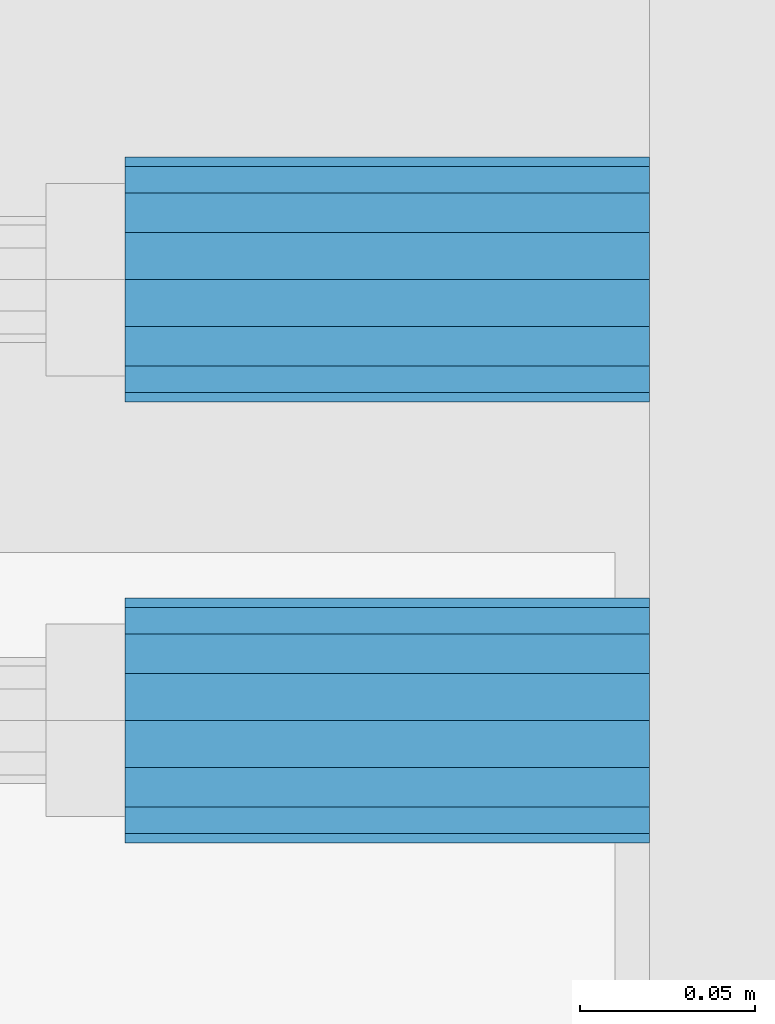
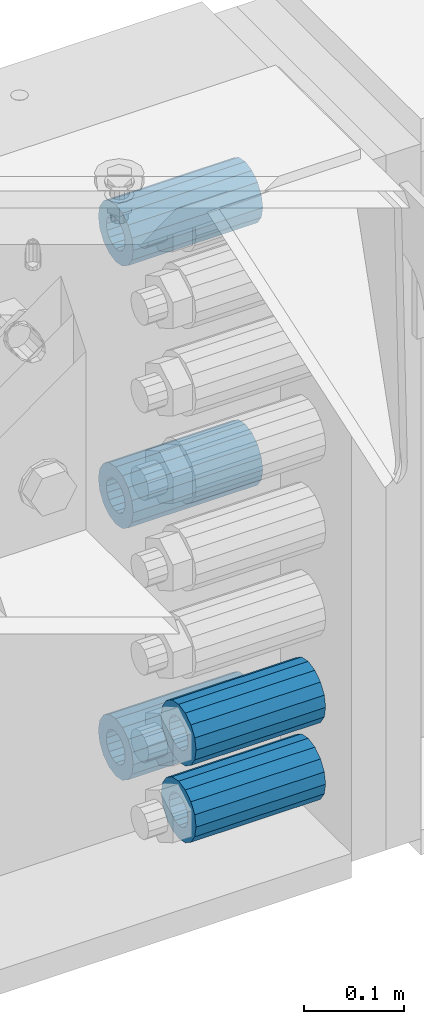
# One storey, part 178 of 257: 5 beams.
"""IFC2X3 building model written with IfcOpenShell, lengths in millimetres."""

import ifcopenshell
import ifcopenshell.guid

model = None  # the IFC model being written
_history = None  # IfcOwnerHistory: only IFC2X3 demands one
_inside = {}  # id of a spatial element -> (the spatial element, [elements in it])
_under = {}  # id of a project, library or spatial element -> (it, [spatial elements below it])
_declared = {}  # id of a project -> (the project, [libraries it declares])
_typed = {}  # id of a type object -> (the type object, [elements of that type])
_made_of = {}  # id of a material, layer set ... -> (it, [elements and type objects made of it])


def new_model(schema):
    """Start an empty IFC model of exactly this schema.

    Asked for "IFC4X3", IfcOpenShell would pick the latest addendum, in which some entities
    have other attributes; the version numbers below select the first issue.
    IFC2X3 requires an IfcOwnerHistory on every rooted entity: one is made here for all.
    """
    global model, _history
    if schema == "IFC4X3":
        model = ifcopenshell.file(schema_version=(4, 3, 0, 0))
    else:
        model = ifcopenshell.file(schema=schema)
    _inside.clear()
    _under.clear()
    _declared.clear()
    _typed.clear()
    _made_of.clear()
    _history = None
    if model.schema == "IFC2X3":
        org = make("IfcOrganization", Name="unknown")
        user = make(
            "IfcPersonAndOrganization",
            ThePerson=make("IfcPerson", FamilyName="unknown"),
            TheOrganization=org,
        )
        app = make(
            "IfcApplication",
            ApplicationDeveloper=org,
            Version="unknown",
            ApplicationFullName="unknown",
            ApplicationIdentifier="unknown",
        )
        _history = make(
            "IfcOwnerHistory",
            OwningUser=user,
            OwningApplication=app,
            ChangeAction="ADDED",
            CreationDate=0,
        )
    return model


def make(cls, **values):
    """One entity of the class cls with the attributes given. An attribute that is None is left unset."""
    return model.create_entity(
        cls, **{name: value for name, value in values.items() if value is not None}
    )


def rooted(cls, **values):
    """An entity with a GlobalId (a new one), such as an element, a storey or a relation."""
    return make(cls, GlobalId=ifcopenshell.guid.new(), OwnerHistory=_history, **values)


def si_unit(unit_type, name, prefix=None):
    """IfcSIUnit, for example si_unit("LENGTHUNIT", "METRE", prefix="MILLI")."""
    return make("IfcSIUnit", UnitType=unit_type, Prefix=prefix, Name=name)


def assignment(units):
    """IfcUnitAssignment: the units of a project."""
    return None if units is None else make("IfcUnitAssignment", Units=units)


def point(xyz):
    """IfcCartesianPoint."""
    return None if xyz is None else make("IfcCartesianPoint", Coordinates=xyz)


def direction(xyz):
    """IfcDirection."""
    return None if xyz is None else make("IfcDirection", DirectionRatios=xyz)


def frame(location, z_axis=None, x_axis=None):
    """IfcAxis2Placement3D, a coordinate frame: its origin and axes. An axis left out is left unset."""
    return make(
        "IfcAxis2Placement3D",
        Location=point(location),
        Axis=direction(z_axis),
        RefDirection=direction(x_axis),
    )


def origin_with_axes():
    """The frame at (0, 0, 0) with the z axis (0, 0, 1) and the x axis (1, 0, 0) written out."""
    return frame((0.0, 0.0, 0.0), z_axis=(0.0, 0.0, 1.0), x_axis=(1.0, 0.0, 0.0))


def place(relative_to, where):
    """IfcLocalPlacement: puts the frame where relative to a parent placement (None: the world)."""
    return make(
        "IfcLocalPlacement", PlacementRelTo=relative_to, RelativePlacement=where
    )


def context(
    kind, dimensions, precision=None, world=None, true_north=None, identifier=None
):
    """IfcGeometricRepresentationContext, for example the 3D "Model" context."""
    return make(
        "IfcGeometricRepresentationContext",
        ContextIdentifier=identifier,
        ContextType=kind,
        CoordinateSpaceDimension=dimensions,
        Precision=precision,
        WorldCoordinateSystem=world,
        TrueNorth=true_north,
    )


def subcontext(parent, identifier, kind, view, scale=None):
    """IfcGeometricRepresentationSubContext, for example "Body" below "Model"."""
    return make(
        "IfcGeometricRepresentationSubContext",
        ContextIdentifier=identifier,
        ContextType=kind,
        ParentContext=parent,
        TargetScale=scale,
        TargetView=view,
    )


def project(units=None, contexts=None):
    """IfcProject with its units and contexts."""
    return rooted(
        "IfcProject",
        Name="project",
        RepresentationContexts=contexts,
        UnitsInContext=assignment(units),
    )


def spatial(cls, under=None, at=None, **own):
    """A site, building, storey or space (cls), placed at a placement, below another one or the project."""
    s = rooted(cls, ObjectPlacement=at, **own)
    if under is not None:
        _under.setdefault(under.id(), (under, []))[1].append(s)
    return s


def faces_of(points, faces, orient=None, outer=None):
    """IfcFace entities. A face is a list of loops; a loop is a list of indices into points, from 0.

    orient and outer hold one flag for each loop. By default every Orientation is true, the
    first loop of a face is its IfcFaceOuterBound and the others are IfcFaceBound.
    """
    made = []
    for i, loops in enumerate(faces):
        bounds = []
        for j, loop in enumerate(loops):
            is_outer = j == 0 if outer is None else outer[i][j]
            bounds.append(
                make(
                    "IfcFaceOuterBound" if is_outer else "IfcFaceBound",
                    Bound=make("IfcPolyLoop", Polygon=[points[k] for k in loop]),
                    Orientation=True if orient is None else orient[i][j],
                )
            )
        made.append(make("IfcFace", Bounds=bounds))
    return made


def faceted_brep(points, faces, orient=None, outer=None, voids=None):
    """IfcFacetedBrep: a solid bounded by flat faces; with voids (closed shells), ...WithVoids."""
    shared = [point(p) for p in points]
    hull = make("IfcClosedShell", CfsFaces=faces_of(shared, faces, orient, outer))
    if voids is None:
        return make("IfcFacetedBrep", Outer=hull)
    return make(
        "IfcFacetedBrepWithVoids",
        Outer=hull,
        Voids=[
            make(cls, CfsFaces=faces_of(shared, fs, o, b)) for cls, fs, o, b in voids
        ],
    )


def shape(context_of_items, identifier, shape_type, items):
    """IfcShapeRepresentation: the items that make up one representation, for example the "Body"."""
    return make(
        "IfcShapeRepresentation",
        ContextOfItems=context_of_items,
        RepresentationIdentifier=identifier,
        RepresentationType=shape_type,
        Items=items,
    )


def material(Name=None, Category=None):
    """IfcMaterial."""
    return make("IfcMaterial", Name=Name, Category=Category)


def made_of(thing, what):
    """Note that an element or type object is made of a material, layer set ...; save() writes the relation."""
    if what is not None:
        _made_of.setdefault(what.id(), (what, []))[1].append(thing)
    return thing


def type_object(cls, material=None, **own):
    """A type object (cls), such as IfcWallType, which elements share."""
    return made_of(rooted(cls, **own), material)


def element(
    cls,
    number,
    at=None,
    inside=None,
    cuts=None,
    type_object=None,
    material=None,
    context=None,
    identifier="Body",
    shape_type=None,
    held_by="IfcProductDefinitionShape",
    body=None,
    shapes=None,
    **own,
):
    """One element of the class cls, such as IfcWall. Its Tag is "e" and its number.

    at: its placement. inside: the storey or other place that contains it. cuts: it is an
    opening in that element (IfcRelVoidsElement). A single representation is given by context,
    identifier, shape_type and body (its items); several are given by shapes. held_by: the class
    of the entity that holds the representations. save() writes the other relations.
    """
    e = rooted(cls, Tag="e%d" % number, ObjectPlacement=at, **own)
    if body is not None:
        shapes = [shape(context, identifier, shape_type, body)]
    if shapes is not None:
        e.Representation = make(held_by, Representations=shapes)
    if inside is not None:
        _inside.setdefault(inside.id(), (inside, []))[1].append(e)
    if cuts is not None:
        rooted(
            "IfcRelVoidsElement", RelatingBuildingElement=cuts, RelatedOpeningElement=e
        )
    if type_object is not None:
        _typed.setdefault(type_object.id(), (type_object, []))[1].append(e)
    return made_of(e, material)


def aggregate(whole, parts):
    """IfcRelAggregates: a whole, such as a stair, and the parts it consists of."""
    return rooted("IfcRelAggregates", RelatingObject=whole, RelatedObjects=parts)


def save(model, path):
    """Write the relations noted so far, then the file.

    IfcRelAggregates (storeys below a building ...), IfcRelContainedInSpatialStructure (elements
    in a storey), IfcRelDefinesByType, IfcRelAssociatesMaterial and IfcRelDeclares: one each for
    every whole, place, type object, material and project.
    """
    for whole, parts in _under.values():
        aggregate(whole, parts)
    for where, things in _inside.values():
        rooted(
            "IfcRelContainedInSpatialStructure",
            RelatedElements=things,
            RelatingStructure=where,
        )
    for kind, things in _typed.values():
        rooted("IfcRelDefinesByType", RelatedObjects=things, RelatingType=kind)
    for what, things in _made_of.values():
        rooted("IfcRelAssociatesMaterial", RelatedObjects=things, RelatingMaterial=what)
    for by, libraries in _declared.values():
        rooted("IfcRelDeclares", RelatingContext=by, RelatedDefinitions=libraries)
    model.write(path)


model = new_model("IFC2X3")

# Units and contexts
model_context = context("Model", 3, precision=1e-05, world=origin_with_axes())
body_context = subcontext(model_context, "Body", "Model", "MODEL_VIEW")
ifc_project = project(units=[si_unit("LENGTHUNIT", "METRE", prefix="MILLI"), si_unit("AREAUNIT", "SQUARE_METRE"), si_unit("VOLUMEUNIT", "CUBIC_METRE"), si_unit("MASSUNIT", "GRAM", prefix="KILO"), si_unit("TIMEUNIT", "SECOND"), si_unit("PLANEANGLEUNIT", "RADIAN"), si_unit("SOLIDANGLEUNIT", "STERADIAN"), si_unit("THERMODYNAMICTEMPERATUREUNIT", "DEGREE_CELSIUS"), si_unit("LUMINOUSINTENSITYUNIT", "LUMEN")], contexts=[model_context])

# Site, building, storey
site_placement = place(None, origin_with_axes())
site = spatial("IfcSite", under=ifc_project, at=site_placement, CompositionType="ELEMENT")
building_placement = place(site_placement, origin_with_axes())
building = spatial("IfcBuilding", under=site, at=building_placement, Name="Standard", CompositionType="ELEMENT")
storey_placement = place(building_placement, origin_with_axes())
storey = spatial("IfcBuildingStorey", under=building, at=storey_placement, Name="Undefined", CompositionType="ELEMENT", Elevation=0.0)

# Beams
ifc_material = material()
beam_type = type_object("IfcBeamType", PredefinedType="NOTDEFINED")
beam_1_placement = place(storey_placement, frame((59117.0, 12063.0, -499.0), z_axis=(0.0, 0.0, 1.0), x_axis=(1.0, 0.0, 0.0)))
element("IfcBeam", 1, at=beam_1_placement, inside=storey, type_object=beam_type, material=ifc_material, context=body_context, shape_type="Brep", body=[
    faceted_brep([(-1.3120632047503e-07, -18.9999999995493, -6.27187546342611e-09), (0.0, -17.5537111177146, 7.27098521493672), (150.0, -17.5537111177146, 7.27098521493672), (150.0, -19.0, 0.0), (0.0, -13.4350288425449, 13.4350288425444), (150.0, -13.4350288425449, 13.4350288425444), (0.0, -7.27098521493645, 17.5537111177144), (150.0, -7.27098521493645, 17.5537111177144), (-6.33792751614237e-09, 4.50654624728486e-10, 18.9999999937208), (150.0, 0.0, 19.0), (0.0, 7.27098521493645, 17.5537111177144), (150.0, 7.27098521493645, 17.5537111177144), (0.0, 13.4350288425449, 13.4350288425444), (150.0, 13.4350288425449, 13.4350288425444), (0.0, 17.5537111177146, 7.2709852149367), (150.0, 17.5537111177146, 7.2709852149367), (1.33208345687308e-07, 19.0000000004507, -6.27187546342611e-09), (150.0, 19.0, 0.0), (0.0, 17.5537111177146, -7.2709852149367), (150.0, 17.5537111177146, -7.2709852149367), (0.0, 13.4350288425449, -13.4350288425444), (150.0, 13.4350288425449, -13.4350288425444), (0.0, 7.27098521493645, -17.5537111177144), (150.0, 7.27098521493645, -17.5537111177144), (8.33983904158231e-09, 4.50654624728486e-10, -19.0000000062719), (150.0, 0.0, -19.0), (0.0, -7.27098521493645, -17.5537111177144), (150.0, -7.27098521493645, -17.5537111177144), (0.0, -13.4350288425449, -13.4350288425444), (150.0, -13.4350288425449, -13.4350288425444), (0.0, -17.5537111177146, -7.2709852149367), (150.0, -17.5537111177146, -7.2709852149367), (7.27595761418343e-12, -35.0, 0.0), (1.45519152283669e-11, -32.335783637895, -13.3939201327781), (150.0, -32.3357836378955, -13.3939201327782), (150.0, -35.0, 0.0), (7.27595761418343e-12, -24.7487373415292, -24.748737341529), (150.0, -24.7487373415288, -24.7487373415292), (7.27595761418343e-12, -13.3939201327781, -32.335783637895), (150.0, -13.3939201327785, -32.335783637895), (7.27595761418343e-12, 0.0, -35.0), (150.0, 0.0, -35.0), (7.27595761418343e-12, 13.3939201327782, -32.335783637895), (150.0, 13.3939201327785, -32.335783637895), (7.27595761418343e-12, 24.7487373415292, -24.748737341529), (150.0, 24.7487373415288, -24.7487373415292), (1.45519152283669e-11, 32.335783637895, -13.3939201327781), (150.0, 32.3357836378955, -13.3939201327781), (7.27595761418343e-12, 35.0, 0.0), (150.0, 35.0, 0.0), (7.27595761418343e-12, 32.335783637895, 13.3939201327782), (150.0, 32.3357836378955, 13.3939201327781), (7.27595761418343e-12, 24.7487373415292, 24.7487373415291), (150.0, 24.7487373415288, 24.7487373415292), (1.45519152283669e-11, 13.3939201327781, 32.335783637895), (150.0, 13.3939201327785, 32.335783637895), (1.45519152283669e-11, 0.0, 35.0000000000001), (150.0, 0.0, 35.0), (1.45519152283669e-11, -13.3939201327781, 32.335783637895), (150.0, -13.3939201327785, 32.335783637895), (7.27595761418343e-12, -24.7487373415292, 24.7487373415291), (150.0, -24.7487373415288, 24.7487373415292), (7.27595761418343e-12, -32.335783637895, 13.3939201327782), (150.0, -32.3357836378955, 13.3939201327781)], [[[0, 1, 2, 3]], [[1, 4, 5, 2]], [[4, 6, 7, 5]], [[6, 8, 9, 7]], [[8, 10, 11, 9]], [[10, 12, 13, 11]], [[12, 14, 15, 13]], [[14, 16, 17, 15]], [[16, 18, 19, 17]], [[18, 20, 21, 19]], [[20, 22, 23, 21]], [[22, 24, 25, 23]], [[24, 26, 27, 25]], [[26, 28, 29, 27]], [[28, 30, 31, 29]], [[30, 0, 3, 31]], [[32, 33, 34, 35]], [[33, 36, 37, 34]], [[36, 38, 39, 37]], [[38, 40, 41, 39]], [[40, 42, 43, 41]], [[42, 44, 45, 43]], [[44, 46, 47, 45]], [[46, 48, 49, 47]], [[48, 50, 51, 49]], [[50, 52, 53, 51]], [[52, 54, 55, 53]], [[54, 56, 57, 55]], [[56, 58, 59, 57]], [[58, 60, 61, 59]], [[60, 62, 63, 61]], [[62, 32, 35, 63]], [[37, 39, 41, 43, 45, 47, 49, 51, 53, 55, 57, 59, 61, 63, 35, 34], [5, 7, 9, 11, 13, 15, 17, 19, 21, 23, 25, 27, 29, 31, 3, 2]], [[62, 60, 58, 56, 54, 52, 50, 48, 46, 44, 42, 40, 38, 36, 33, 32], [30, 28, 26, 24, 22, 20, 18, 16, 14, 12, 10, 8, 6, 4, 1, 0]]]),
])
beam_2_placement = place(storey_placement, frame((59117.0, 12063.0, -178.0), z_axis=(0.0, 0.0, 1.0), x_axis=(1.0, 0.0, 0.0)))
element("IfcBeam", 2, at=beam_2_placement, inside=storey, type_object=beam_type, material=ifc_material, context=body_context, shape_type="Brep", body=[
    faceted_brep([(-1.3120632047503e-07, -18.9999999995493, -6.27187546342611e-09), (0.0, -17.5537111177146, 7.27098521493672), (150.0, -17.5537111177146, 7.27098521493672), (150.0, -19.0, 0.0), (0.0, -13.4350288425449, 13.4350288425444), (150.0, -13.4350288425449, 13.4350288425444), (0.0, -7.27098521493645, 17.5537111177144), (150.0, -7.27098521493645, 17.5537111177144), (-6.33792751614237e-09, 4.50654624728486e-10, 18.9999999937208), (150.0, 0.0, 19.0), (0.0, 7.27098521493645, 17.5537111177144), (150.0, 7.27098521493645, 17.5537111177144), (0.0, 13.4350288425449, 13.4350288425444), (150.0, 13.4350288425449, 13.4350288425444), (0.0, 17.5537111177146, 7.2709852149367), (150.0, 17.5537111177146, 7.2709852149367), (1.33208345687308e-07, 19.0000000004507, -6.27187546342611e-09), (150.0, 19.0, 0.0), (0.0, 17.5537111177146, -7.2709852149367), (150.0, 17.5537111177146, -7.2709852149367), (0.0, 13.4350288425449, -13.4350288425444), (150.0, 13.4350288425449, -13.4350288425444), (0.0, 7.27098521493645, -17.5537111177144), (150.0, 7.27098521493645, -17.5537111177144), (8.33983904158231e-09, 4.50654624728486e-10, -19.0000000062719), (150.0, 0.0, -19.0), (0.0, -7.27098521493645, -17.5537111177144), (150.0, -7.27098521493645, -17.5537111177144), (0.0, -13.4350288425449, -13.4350288425444), (150.0, -13.4350288425449, -13.4350288425444), (0.0, -17.5537111177146, -7.2709852149367), (150.0, -17.5537111177146, -7.2709852149367), (7.27595761418343e-12, -35.0, 0.0), (1.45519152283669e-11, -32.335783637895, -13.3939201327781), (150.0, -32.3357836378955, -13.3939201327782), (150.0, -35.0, 0.0), (7.27595761418343e-12, -24.7487373415292, -24.748737341529), (150.0, -24.7487373415288, -24.7487373415292), (7.27595761418343e-12, -13.3939201327781, -32.335783637895), (150.0, -13.3939201327785, -32.335783637895), (7.27595761418343e-12, 0.0, -35.0), (150.0, 0.0, -35.0), (7.27595761418343e-12, 13.3939201327782, -32.335783637895), (150.0, 13.3939201327785, -32.335783637895), (7.27595761418343e-12, 24.7487373415292, -24.748737341529), (150.0, 24.7487373415288, -24.7487373415292), (1.45519152283669e-11, 32.335783637895, -13.3939201327781), (150.0, 32.3357836378955, -13.3939201327781), (7.27595761418343e-12, 35.0, 0.0), (150.0, 35.0, 0.0), (7.27595761418343e-12, 32.335783637895, 13.3939201327782), (150.0, 32.3357836378955, 13.3939201327781), (7.27595761418343e-12, 24.7487373415292, 24.7487373415291), (150.0, 24.7487373415288, 24.7487373415292), (1.45519152283669e-11, 13.3939201327781, 32.335783637895), (150.0, 13.3939201327785, 32.335783637895), (1.45519152283669e-11, 0.0, 35.0000000000001), (150.0, 0.0, 35.0), (1.45519152283669e-11, -13.3939201327781, 32.335783637895), (150.0, -13.3939201327785, 32.335783637895), (7.27595761418343e-12, -24.7487373415292, 24.7487373415291), (150.0, -24.7487373415288, 24.7487373415292), (7.27595761418343e-12, -32.335783637895, 13.3939201327782), (150.0, -32.3357836378955, 13.3939201327781)], [[[0, 1, 2, 3]], [[1, 4, 5, 2]], [[4, 6, 7, 5]], [[6, 8, 9, 7]], [[8, 10, 11, 9]], [[10, 12, 13, 11]], [[12, 14, 15, 13]], [[14, 16, 17, 15]], [[16, 18, 19, 17]], [[18, 20, 21, 19]], [[20, 22, 23, 21]], [[22, 24, 25, 23]], [[24, 26, 27, 25]], [[26, 28, 29, 27]], [[28, 30, 31, 29]], [[30, 0, 3, 31]], [[32, 33, 34, 35]], [[33, 36, 37, 34]], [[36, 38, 39, 37]], [[38, 40, 41, 39]], [[40, 42, 43, 41]], [[42, 44, 45, 43]], [[44, 46, 47, 45]], [[46, 48, 49, 47]], [[48, 50, 51, 49]], [[50, 52, 53, 51]], [[52, 54, 55, 53]], [[54, 56, 57, 55]], [[56, 58, 59, 57]], [[58, 60, 61, 59]], [[60, 62, 63, 61]], [[62, 32, 35, 63]], [[37, 39, 41, 43, 45, 47, 49, 51, 53, 55, 57, 59, 61, 63, 35, 34], [5, 7, 9, 11, 13, 15, 17, 19, 21, 23, 25, 27, 29, 31, 3, 2]], [[62, 60, 58, 56, 54, 52, 50, 48, 46, 44, 42, 40, 38, 36, 33, 32], [30, 28, 26, 24, 22, 20, 18, 16, 14, 12, 10, 8, 6, 4, 1, 0]]]),
])
beam_3_placement = place(storey_placement, frame((59117.0, 11937.0, -713.0), z_axis=(0.0, 0.0, 1.0), x_axis=(1.0, 0.0, 0.0)))
element("IfcBeam", 3, at=beam_3_placement, inside=storey, type_object=beam_type, material=ifc_material, context=body_context, shape_type="Brep", body=[
    faceted_brep([(-1.3120632047503e-07, -18.9999999995493, -6.27187546342611e-09), (0.0, -17.5537111177146, 7.27098521493672), (150.0, -17.5537111177146, 7.27098521493672), (150.0, -19.0, 0.0), (0.0, -13.4350288425449, 13.4350288425444), (150.0, -13.4350288425449, 13.4350288425444), (0.0, -7.27098521493645, 17.5537111177144), (150.0, -7.27098521493645, 17.5537111177144), (-6.33792751614237e-09, 4.50654624728486e-10, 18.9999999937208), (150.0, 0.0, 19.0), (0.0, 7.27098521493645, 17.5537111177144), (150.0, 7.27098521493645, 17.5537111177144), (0.0, 13.4350288425449, 13.4350288425444), (150.0, 13.4350288425449, 13.4350288425444), (0.0, 17.5537111177146, 7.2709852149367), (150.0, 17.5537111177146, 7.2709852149367), (1.33208345687308e-07, 19.0000000004507, -6.27187546342611e-09), (150.0, 19.0, 0.0), (0.0, 17.5537111177146, -7.2709852149367), (150.0, 17.5537111177146, -7.2709852149367), (0.0, 13.4350288425449, -13.4350288425444), (150.0, 13.4350288425449, -13.4350288425444), (0.0, 7.27098521493645, -17.5537111177144), (150.0, 7.27098521493645, -17.5537111177144), (8.33983904158231e-09, 4.50654624728486e-10, -19.0000000062719), (150.0, 0.0, -19.0), (0.0, -7.27098521493645, -17.5537111177144), (150.0, -7.27098521493645, -17.5537111177144), (0.0, -13.4350288425449, -13.4350288425444), (150.0, -13.4350288425449, -13.4350288425444), (0.0, -17.5537111177146, -7.2709852149367), (150.0, -17.5537111177146, -7.2709852149367), (7.27595761418343e-12, -35.0, 0.0), (1.45519152283669e-11, -32.335783637895, -13.3939201327781), (150.0, -32.3357836378955, -13.3939201327782), (150.0, -35.0, 0.0), (7.27595761418343e-12, -24.7487373415292, -24.748737341529), (150.0, -24.7487373415288, -24.7487373415292), (7.27595761418343e-12, -13.3939201327781, -32.335783637895), (150.0, -13.3939201327785, -32.335783637895), (7.27595761418343e-12, 0.0, -35.0), (150.0, 0.0, -35.0), (7.27595761418343e-12, 13.3939201327782, -32.335783637895), (150.0, 13.3939201327785, -32.335783637895), (7.27595761418343e-12, 24.7487373415292, -24.748737341529), (150.0, 24.7487373415288, -24.7487373415292), (1.45519152283669e-11, 32.335783637895, -13.3939201327781), (150.0, 32.3357836378955, -13.3939201327781), (7.27595761418343e-12, 35.0, 0.0), (150.0, 35.0, 0.0), (7.27595761418343e-12, 32.335783637895, 13.3939201327782), (150.0, 32.3357836378955, 13.3939201327781), (7.27595761418343e-12, 24.7487373415292, 24.7487373415291), (150.0, 24.7487373415288, 24.7487373415292), (1.45519152283669e-11, 13.3939201327781, 32.335783637895), (150.0, 13.3939201327785, 32.335783637895), (1.45519152283669e-11, 0.0, 35.0000000000001), (150.0, 0.0, 35.0), (1.45519152283669e-11, -13.3939201327781, 32.335783637895), (150.0, -13.3939201327785, 32.335783637895), (7.27595761418343e-12, -24.7487373415292, 24.7487373415291), (150.0, -24.7487373415288, 24.7487373415292), (7.27595761418343e-12, -32.335783637895, 13.3939201327782), (150.0, -32.3357836378955, 13.3939201327781)], [[[0, 1, 2, 3]], [[1, 4, 5, 2]], [[4, 6, 7, 5]], [[6, 8, 9, 7]], [[8, 10, 11, 9]], [[10, 12, 13, 11]], [[12, 14, 15, 13]], [[14, 16, 17, 15]], [[16, 18, 19, 17]], [[18, 20, 21, 19]], [[20, 22, 23, 21]], [[22, 24, 25, 23]], [[24, 26, 27, 25]], [[26, 28, 29, 27]], [[28, 30, 31, 29]], [[30, 0, 3, 31]], [[32, 33, 34, 35]], [[33, 36, 37, 34]], [[36, 38, 39, 37]], [[38, 40, 41, 39]], [[40, 42, 43, 41]], [[42, 44, 45, 43]], [[44, 46, 47, 45]], [[46, 48, 49, 47]], [[48, 50, 51, 49]], [[50, 52, 53, 51]], [[52, 54, 55, 53]], [[54, 56, 57, 55]], [[56, 58, 59, 57]], [[58, 60, 61, 59]], [[60, 62, 63, 61]], [[62, 32, 35, 63]], [[37, 39, 41, 43, 45, 47, 49, 51, 53, 55, 57, 59, 61, 63, 35, 34], [5, 7, 9, 11, 13, 15, 17, 19, 21, 23, 25, 27, 29, 31, 3, 2]], [[62, 60, 58, 56, 54, 52, 50, 48, 46, 44, 42, 40, 38, 36, 33, 32], [30, 28, 26, 24, 22, 20, 18, 16, 14, 12, 10, 8, 6, 4, 1, 0]]]),
])
beam_4_placement = place(storey_placement, frame((59117.0, 12063.0, -807.0), z_axis=(0.0, 0.0, 1.0), x_axis=(1.0, 0.0, 0.0)))
element("IfcBeam", 4, at=beam_4_placement, inside=storey, type_object=beam_type, material=ifc_material, context=body_context, shape_type="Brep", body=[
    faceted_brep([(-1.3120632047503e-07, -18.9999999995493, -6.27187546342611e-09), (0.0, -17.5537111177146, 7.27098521493672), (150.0, -17.5537111177146, 7.27098521493672), (150.0, -19.0, 0.0), (0.0, -13.4350288425449, 13.4350288425444), (150.0, -13.4350288425449, 13.4350288425444), (0.0, -7.27098521493645, 17.5537111177144), (150.0, -7.27098521493645, 17.5537111177144), (-6.33792751614237e-09, 4.50654624728486e-10, 18.9999999937208), (150.0, 0.0, 19.0), (0.0, 7.27098521493645, 17.5537111177144), (150.0, 7.27098521493645, 17.5537111177144), (0.0, 13.4350288425449, 13.4350288425444), (150.0, 13.4350288425449, 13.4350288425444), (0.0, 17.5537111177146, 7.2709852149367), (150.0, 17.5537111177146, 7.2709852149367), (1.33208345687308e-07, 19.0000000004507, -6.27187546342611e-09), (150.0, 19.0, 0.0), (0.0, 17.5537111177146, -7.2709852149367), (150.0, 17.5537111177146, -7.2709852149367), (0.0, 13.4350288425449, -13.4350288425444), (150.0, 13.4350288425449, -13.4350288425444), (0.0, 7.27098521493645, -17.5537111177144), (150.0, 7.27098521493645, -17.5537111177144), (8.33983904158231e-09, 4.50654624728486e-10, -19.0000000062719), (150.0, 0.0, -19.0), (0.0, -7.27098521493645, -17.5537111177144), (150.0, -7.27098521493645, -17.5537111177144), (0.0, -13.4350288425449, -13.4350288425444), (150.0, -13.4350288425449, -13.4350288425444), (0.0, -17.5537111177146, -7.2709852149367), (150.0, -17.5537111177146, -7.2709852149367), (7.27595761418343e-12, -35.0, 0.0), (1.45519152283669e-11, -32.335783637895, -13.3939201327781), (150.0, -32.3357836378955, -13.3939201327782), (150.0, -35.0, 0.0), (7.27595761418343e-12, -24.7487373415292, -24.748737341529), (150.0, -24.7487373415288, -24.7487373415292), (7.27595761418343e-12, -13.3939201327781, -32.335783637895), (150.0, -13.3939201327785, -32.335783637895), (7.27595761418343e-12, 0.0, -35.0), (150.0, 0.0, -35.0), (7.27595761418343e-12, 13.3939201327782, -32.335783637895), (150.0, 13.3939201327785, -32.335783637895), (7.27595761418343e-12, 24.7487373415292, -24.748737341529), (150.0, 24.7487373415288, -24.7487373415292), (1.45519152283669e-11, 32.335783637895, -13.3939201327781), (150.0, 32.3357836378955, -13.3939201327781), (7.27595761418343e-12, 35.0, 0.0), (150.0, 35.0, 0.0), (7.27595761418343e-12, 32.335783637895, 13.3939201327782), (150.0, 32.3357836378955, 13.3939201327781), (7.27595761418343e-12, 24.7487373415292, 24.7487373415291), (150.0, 24.7487373415288, 24.7487373415292), (1.45519152283669e-11, 13.3939201327781, 32.335783637895), (150.0, 13.3939201327785, 32.335783637895), (1.45519152283669e-11, 0.0, 35.0000000000001), (150.0, 0.0, 35.0), (1.45519152283669e-11, -13.3939201327781, 32.335783637895), (150.0, -13.3939201327785, 32.335783637895), (7.27595761418343e-12, -24.7487373415292, 24.7487373415291), (150.0, -24.7487373415288, 24.7487373415292), (7.27595761418343e-12, -32.335783637895, 13.3939201327782), (150.0, -32.3357836378955, 13.3939201327781)], [[[0, 1, 2, 3]], [[1, 4, 5, 2]], [[4, 6, 7, 5]], [[6, 8, 9, 7]], [[8, 10, 11, 9]], [[10, 12, 13, 11]], [[12, 14, 15, 13]], [[14, 16, 17, 15]], [[16, 18, 19, 17]], [[18, 20, 21, 19]], [[20, 22, 23, 21]], [[22, 24, 25, 23]], [[24, 26, 27, 25]], [[26, 28, 29, 27]], [[28, 30, 31, 29]], [[30, 0, 3, 31]], [[32, 33, 34, 35]], [[33, 36, 37, 34]], [[36, 38, 39, 37]], [[38, 40, 41, 39]], [[40, 42, 43, 41]], [[42, 44, 45, 43]], [[44, 46, 47, 45]], [[46, 48, 49, 47]], [[48, 50, 51, 49]], [[50, 52, 53, 51]], [[52, 54, 55, 53]], [[54, 56, 57, 55]], [[56, 58, 59, 57]], [[58, 60, 61, 59]], [[60, 62, 63, 61]], [[62, 32, 35, 63]], [[37, 39, 41, 43, 45, 47, 49, 51, 53, 55, 57, 59, 61, 63, 35, 34], [5, 7, 9, 11, 13, 15, 17, 19, 21, 23, 25, 27, 29, 31, 3, 2]], [[62, 60, 58, 56, 54, 52, 50, 48, 46, 44, 42, 40, 38, 36, 33, 32], [30, 28, 26, 24, 22, 20, 18, 16, 14, 12, 10, 8, 6, 4, 1, 0]]]),
])
beam_5_placement = place(storey_placement, frame((59117.0, 11937.0, -807.0), z_axis=(0.0, 0.0, 1.0), x_axis=(1.0, 0.0, 0.0)))
element("IfcBeam", 5, at=beam_5_placement, inside=storey, type_object=beam_type, material=ifc_material, context=body_context, shape_type="Brep", body=[
    faceted_brep([(-1.3120632047503e-07, -18.9999999995493, -6.27187546342611e-09), (0.0, -17.5537111177146, 7.27098521493672), (150.0, -17.5537111177146, 7.27098521493672), (150.0, -19.0, 0.0), (0.0, -13.4350288425449, 13.4350288425444), (150.0, -13.4350288425449, 13.4350288425444), (0.0, -7.27098521493645, 17.5537111177144), (150.0, -7.27098521493645, 17.5537111177144), (-6.33792751614237e-09, 4.50654624728486e-10, 18.9999999937208), (150.0, 0.0, 19.0), (0.0, 7.27098521493645, 17.5537111177144), (150.0, 7.27098521493645, 17.5537111177144), (0.0, 13.4350288425449, 13.4350288425444), (150.0, 13.4350288425449, 13.4350288425444), (0.0, 17.5537111177146, 7.2709852149367), (150.0, 17.5537111177146, 7.2709852149367), (1.33208345687308e-07, 19.0000000004507, -6.27187546342611e-09), (150.0, 19.0, 0.0), (0.0, 17.5537111177146, -7.2709852149367), (150.0, 17.5537111177146, -7.2709852149367), (0.0, 13.4350288425449, -13.4350288425444), (150.0, 13.4350288425449, -13.4350288425444), (0.0, 7.27098521493645, -17.5537111177144), (150.0, 7.27098521493645, -17.5537111177144), (8.33983904158231e-09, 4.50654624728486e-10, -19.0000000062719), (150.0, 0.0, -19.0), (0.0, -7.27098521493645, -17.5537111177144), (150.0, -7.27098521493645, -17.5537111177144), (0.0, -13.4350288425449, -13.4350288425444), (150.0, -13.4350288425449, -13.4350288425444), (0.0, -17.5537111177146, -7.2709852149367), (150.0, -17.5537111177146, -7.2709852149367), (7.27595761418343e-12, -35.0, 0.0), (1.45519152283669e-11, -32.335783637895, -13.3939201327781), (150.0, -32.3357836378955, -13.3939201327782), (150.0, -35.0, 0.0), (7.27595761418343e-12, -24.7487373415292, -24.748737341529), (150.0, -24.7487373415288, -24.7487373415292), (7.27595761418343e-12, -13.3939201327781, -32.335783637895), (150.0, -13.3939201327785, -32.335783637895), (7.27595761418343e-12, 0.0, -35.0), (150.0, 0.0, -35.0), (7.27595761418343e-12, 13.3939201327782, -32.335783637895), (150.0, 13.3939201327785, -32.335783637895), (7.27595761418343e-12, 24.7487373415292, -24.748737341529), (150.0, 24.7487373415288, -24.7487373415292), (1.45519152283669e-11, 32.335783637895, -13.3939201327781), (150.0, 32.3357836378955, -13.3939201327781), (7.27595761418343e-12, 35.0, 0.0), (150.0, 35.0, 0.0), (7.27595761418343e-12, 32.335783637895, 13.3939201327782), (150.0, 32.3357836378955, 13.3939201327781), (7.27595761418343e-12, 24.7487373415292, 24.7487373415291), (150.0, 24.7487373415288, 24.7487373415292), (1.45519152283669e-11, 13.3939201327781, 32.335783637895), (150.0, 13.3939201327785, 32.335783637895), (1.45519152283669e-11, 0.0, 35.0000000000001), (150.0, 0.0, 35.0), (1.45519152283669e-11, -13.3939201327781, 32.335783637895), (150.0, -13.3939201327785, 32.335783637895), (7.27595761418343e-12, -24.7487373415292, 24.7487373415291), (150.0, -24.7487373415288, 24.7487373415292), (7.27595761418343e-12, -32.335783637895, 13.3939201327782), (150.0, -32.3357836378955, 13.3939201327781)], [[[0, 1, 2, 3]], [[1, 4, 5, 2]], [[4, 6, 7, 5]], [[6, 8, 9, 7]], [[8, 10, 11, 9]], [[10, 12, 13, 11]], [[12, 14, 15, 13]], [[14, 16, 17, 15]], [[16, 18, 19, 17]], [[18, 20, 21, 19]], [[20, 22, 23, 21]], [[22, 24, 25, 23]], [[24, 26, 27, 25]], [[26, 28, 29, 27]], [[28, 30, 31, 29]], [[30, 0, 3, 31]], [[32, 33, 34, 35]], [[33, 36, 37, 34]], [[36, 38, 39, 37]], [[38, 40, 41, 39]], [[40, 42, 43, 41]], [[42, 44, 45, 43]], [[44, 46, 47, 45]], [[46, 48, 49, 47]], [[48, 50, 51, 49]], [[50, 52, 53, 51]], [[52, 54, 55, 53]], [[54, 56, 57, 55]], [[56, 58, 59, 57]], [[58, 60, 61, 59]], [[60, 62, 63, 61]], [[62, 32, 35, 63]], [[37, 39, 41, 43, 45, 47, 49, 51, 53, 55, 57, 59, 61, 63, 35, 34], [5, 7, 9, 11, 13, 15, 17, 19, 21, 23, 25, 27, 29, 31, 3, 2]], [[62, 60, 58, 56, 54, 52, 50, 48, 46, 44, 42, 40, 38, 36, 33, 32], [30, 28, 26, 24, 22, 20, 18, 16, 14, 12, 10, 8, 6, 4, 1, 0]]]),
])

save(model, "model.ifc")
